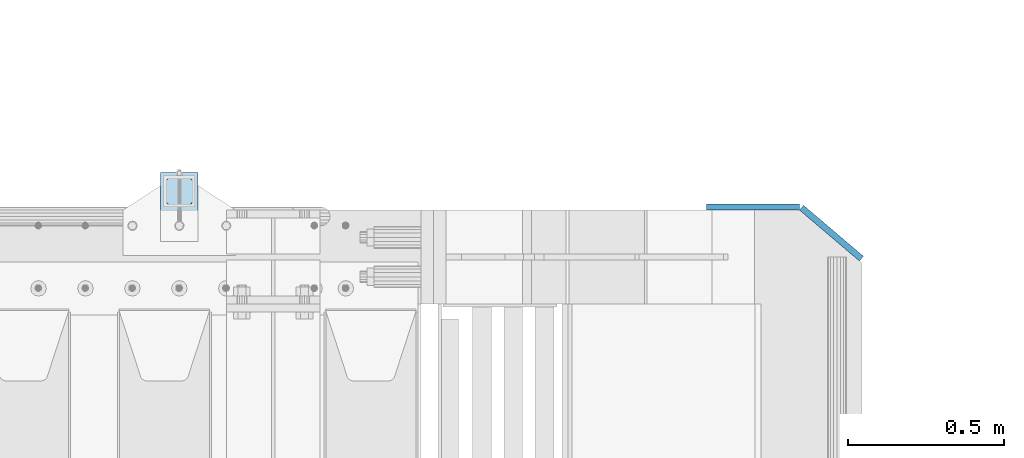
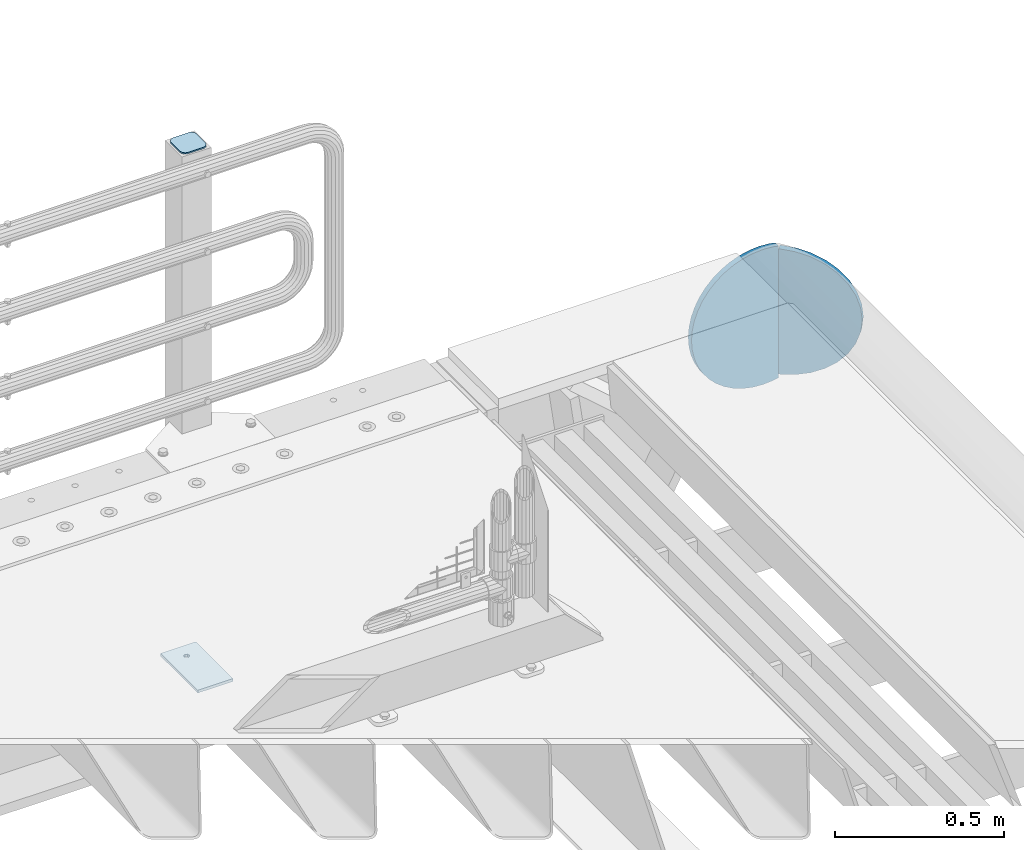
# One storey, part 253 of 270: 4 plates.
"""IFC2X3 building model written with IfcOpenShell, lengths in millimetres."""

from ifc_helpers import new_model, si_unit, frame, origin_with_axes, place, context, subcontext, project, spatial, faceted_brep, material, type_object, element, save


model = new_model("IFC2X3")

# Units and contexts
model_context = context("Model", 3, precision=1e-05, world=origin_with_axes())
body_context = subcontext(model_context, "Body", "Model", "MODEL_VIEW")
ifc_project = project(units=[si_unit("LENGTHUNIT", "METRE", prefix="MILLI"), si_unit("AREAUNIT", "SQUARE_METRE"), si_unit("VOLUMEUNIT", "CUBIC_METRE"), si_unit("MASSUNIT", "GRAM", prefix="KILO"), si_unit("TIMEUNIT", "SECOND"), si_unit("PLANEANGLEUNIT", "RADIAN"), si_unit("SOLIDANGLEUNIT", "STERADIAN"), si_unit("THERMODYNAMICTEMPERATUREUNIT", "DEGREE_CELSIUS"), si_unit("LUMINOUSINTENSITYUNIT", "LUMEN")], contexts=[model_context])

# Site, building, storey
site_placement = place(None, origin_with_axes())
site = spatial("IfcSite", under=ifc_project, at=site_placement, CompositionType="ELEMENT")
building_placement = place(site_placement, origin_with_axes())
building = spatial("IfcBuilding", under=site, at=building_placement, Name="Standard", CompositionType="ELEMENT")
storey_placement = place(building_placement, origin_with_axes())
storey = spatial("IfcBuildingStorey", under=building, at=storey_placement, Name="Undefined", CompositionType="ELEMENT", Elevation=0.0)

# Plates
ifc_material_1 = material(Name="STEEL/S355J2")
plate_type_1 = type_object("IfcPlateType", PredefinedType="NOTDEFINED")
plate_1_placement = place(storey_placement, frame((19558.0000000001, -14949.9999999998, -850.000000000002), z_axis=(0.0, 1.0, 0.0), x_axis=(1.0, 0.0, 0.0)))
element("IfcPlate", 1, at=plate_1_placement, inside=storey, type_object=plate_type_1, material=ifc_material_1, context=body_context, shape_type="Brep", body=[
    faceted_brep([(66.3639610305399, -5.0, 163.636038969114), (66.3639610305399, 5.0, 163.636038969114), (59.9999999998618, 5.0, 160.999999999793), (59.9999999998618, -5.0, 160.999999999793), (53.6360389691836, 5.0, 163.636038969114), (53.6360389691836, -5.0, 163.636038969114), (50.9999999998618, 5.0, 169.999999999793), (50.9999999998618, -5.0, 169.999999999793), (53.6360389691836, 5.0, 176.363961030471), (53.6360389691836, -5.0, 176.363961030471), (59.9999999998618, 5.0, 178.999999999793), (59.9999999998618, -5.0, 178.999999999793), (66.3639610305399, 5.0, 176.363961030471), (66.3639610305399, -5.0, 176.363961030471), (68.9999999998618, 5.0, 169.999999999793), (68.9999999998618, -5.0, 169.999999999793), (120.0, -5.0, 0.0), (120.0, -5.0, 220.0), (0.0, -5.0, 220.0), (0.0, -5.0, 0.0), (0.0, 5.0, 0.0), (120.0, 5.0, 0.0), (120.0, 5.0, 220.0), (0.0, 5.0, 220.0)], [[[0, 1, 2, 3]], [[3, 2, 4, 5]], [[5, 4, 6, 7]], [[7, 6, 8, 9]], [[9, 8, 10, 11]], [[11, 10, 12, 13]], [[13, 12, 14, 15]], [[15, 14, 1, 0]], [[16, 17, 18, 19], [3, 5, 7, 9, 11, 13, 15, 0]], [[16, 19, 20, 21]], [[17, 16, 21, 22]], [[18, 17, 22, 23]], [[19, 18, 23, 20]], [[22, 21, 20, 23], [10, 8, 6, 4, 2, 1, 14, 12]]]),
])
plate_type_2 = type_object("IfcPlateType", PredefinedType="NOTDEFINED")
plate_2_placement = place(storey_placement, frame((19662.0000000001, -14833.9999999998, 1012.50000000001), z_axis=(0.0, 1.0, 0.0), x_axis=(-1.0, 0.0, 0.0)))
element("IfcPlate", 2, at=plate_2_placement, inside=storey, type_object=plate_type_2, material=ifc_material_1, context=body_context, shape_type="Brep", body=[
    faceted_brep([(0.0, -2.5, 19.0), (0.0, -2.5, 69.0), (0.0, 2.5, 69.0), (0.0, 2.5, 19.0), (0.476369668544066, -2.5, 73.2278977451697), (0.476369668544066, 2.5, 73.2278977451697), (1.88159150985302, -2.5, 77.2437910432327), (1.88159150985302, 2.5, 77.2437910432327), (4.14520183310742, -2.5, 80.8463062353167), (4.14520183310742, 2.5, 80.8463062353167), (7.15369376468516, -2.5, 83.8547981668926), (7.15369376468516, 2.5, 83.8547981668926), (10.7562089567655, -2.5, 86.1184084901452), (10.7562089567655, 2.5, 86.1184084901452), (14.7721022548285, -2.5, 87.5236303314541), (14.7721022548285, 2.5, 87.5236303314541), (19.0, -2.5, 88.0), (19.0, 2.5, 88.0), (69.0, -2.5, 88.0), (69.0, 2.5, 88.0), (73.2278977451715, -2.5, 87.5236303314541), (73.2278977451715, 2.5, 87.5236303314541), (77.2437910432345, -2.5, 86.1184084901452), (77.2437910432345, 2.5, 86.1184084901452), (80.8463062353148, -2.5, 83.8547981668926), (80.8463062353148, 2.5, 83.8547981668926), (83.8547981668926, -2.5, 80.8463062353167), (83.8547981668926, 2.5, 80.8463062353167), (86.118408490147, -2.5, 77.2437910432345), (86.118408490147, 2.5, 77.2437910432345), (87.5236303314559, -2.5, 73.2278977451697), (87.5236303314559, 2.5, 73.2278977451697), (88.0, -2.5, 69.0), (88.0, 2.5, 69.0), (88.0, -2.5, 19.0), (88.0, 2.5, 19.0), (87.5236303314559, -2.5, 14.7721022548303), (87.5236303314559, 2.5, 14.7721022548303), (86.118408490147, -2.5, 10.7562089567673), (86.118408490147, 2.5, 10.7562089567673), (83.8547981668926, -2.5, 7.15369376468334), (83.8547981668926, 2.5, 7.15369376468334), (80.8463062353148, -2.5, 4.14520183310742), (80.8463062353148, 2.5, 4.14520183310742), (77.2437910432345, -2.5, 1.88159150985484), (77.2437910432345, 2.5, 1.88159150985484), (73.2278977451715, -2.5, 0.476369668545885), (73.2278977451715, 2.5, 0.476369668545885), (69.0, -2.5, 0.0), (69.0, 2.5, 0.0), (19.0, -2.5, 0.0), (19.0, 2.5, 0.0), (14.7721022548285, -2.5, 0.476369668545885), (14.7721022548285, 2.5, 0.476369668545885), (10.7562089567655, -2.5, 1.88159150985484), (10.7562089567655, 2.5, 1.88159150985484), (7.15369376468516, -2.5, 4.14520183310742), (7.15369376468516, 2.5, 4.14520183310742), (4.14520183310742, -2.5, 7.15369376468334), (4.14520183310742, 2.5, 7.15369376468334), (1.88159150985302, -2.5, 10.7562089567673), (1.88159150985302, 2.5, 10.7562089567673), (0.476369668544066, -2.5, 14.7721022548303), (0.476369668544066, 2.5, 14.7721022548303)], [[[0, 1, 2, 3]], [[1, 4, 5, 2]], [[4, 6, 7, 5]], [[6, 8, 9, 7]], [[8, 10, 11, 9]], [[10, 12, 13, 11]], [[12, 14, 15, 13]], [[14, 16, 17, 15]], [[16, 18, 19, 17]], [[18, 20, 21, 19]], [[20, 22, 23, 21]], [[22, 24, 25, 23]], [[24, 26, 27, 25]], [[26, 28, 29, 27]], [[28, 30, 31, 29]], [[30, 32, 33, 31]], [[32, 34, 35, 33]], [[34, 36, 37, 35]], [[36, 38, 39, 37]], [[38, 40, 41, 39]], [[40, 42, 43, 41]], [[42, 44, 45, 43]], [[44, 46, 47, 45]], [[46, 48, 49, 47]], [[48, 50, 51, 49]], [[50, 52, 53, 51]], [[52, 54, 55, 53]], [[54, 56, 57, 55]], [[56, 58, 59, 57]], [[58, 60, 61, 59]], [[60, 62, 63, 61]], [[62, 0, 3, 63]], [[5, 7, 9, 11, 13, 15, 17, 19, 21, 23, 25, 27, 29, 31, 33, 35, 37, 39, 41, 43, 45, 47, 49, 51, 53, 55, 57, 59, 61, 63, 3, 2]], [[62, 60, 58, 56, 54, 52, 50, 48, 46, 44, 42, 40, 38, 36, 34, 32, 30, 28, 26, 24, 22, 20, 18, 16, 14, 12, 10, 8, 6, 4, 1, 0]]]),
])
ifc_material_2 = material(Name="STEEL/S355N")
plate_type_3 = type_object("IfcPlateType", PredefinedType="NOTDEFINED")
plate_3_placement = place(storey_placement, frame((21789.9988298906, -14840.0, -498.000000000001), z_axis=(0.0, 0.0, 1.0), x_axis=(-1.0, 0.0, 0.0)))
element("IfcPlate", 3, at=plate_3_placement, inside=storey, type_object=plate_type_3, material=ifc_material_2, context=body_context, shape_type="Brep", body=[
    faceted_brep([(244.0, -10.0, 0.0), (209.275179461318, -10.0, 2.48356818105242), (209.275179461318, 10.0, 2.48356818105242), (244.0, 10.0, 0.0), (278.724820538682, -10.0, 2.48356818105236), (278.724820538682, 10.0, 2.48356818105236), (312.742743869308, -10.0, 9.88371443806261), (312.742743869308, 10.0, 9.88371443806261), (345.361263172461, -10.0, 22.0497931334975), (345.361263172461, 10.0, 22.0497931334975), (375.916359459166, -10.0, 38.7341379891918), (375.916359459166, 10.0, 38.7341379891918), (403.78601908265, -10.0, 59.597103857561), (403.78601908265, 10.0, 59.597103857561), (428.402896142437, -10.0, 84.2139809173505), (428.402896142437, 10.0, 84.2139809173505), (449.265862010809, -10.0, 112.083640540834), (449.265862010809, 10.0, 112.083640540834), (465.950206866502, -10.0, 142.63873682754), (465.950206866502, 10.0, 142.63873682754), (478.116285561937, -10.0, 175.257256130691), (478.116285561937, 10.0, 175.257256130691), (485.516431818949, -10.0, 209.275179461318), (485.516431818949, 10.0, 209.275179461318), (488.0, -10.0, 244.0), (488.0, 10.0, 244.0), (485.516431818949, -10.0, 278.724820538682), (485.516431818949, 10.0, 278.724820538682), (478.116285561937, -10.0, 312.742743869309), (478.116285561937, 10.0, 312.742743869309), (465.950206866502, -10.0, 345.36126317246), (465.950206866502, 10.0, 345.36126317246), (449.265862010809, -10.0, 375.916359459166), (449.265862010809, 10.0, 375.916359459166), (428.402896142437, -10.0, 403.78601908265), (428.402896142437, 10.0, 403.78601908265), (403.78601908265, -10.0, 428.402896142439), (403.78601908265, 10.0, 428.402896142439), (375.916359459166, -10.0, 449.265862010808), (375.916359459166, 10.0, 449.265862010808), (345.361263172461, -10.0, 465.950206866503), (345.361263172461, 10.0, 465.950206866503), (312.742743869308, -10.0, 478.116285561937), (312.742743869308, 10.0, 478.116285561937), (278.724820538682, -10.0, 485.516431818948), (278.724820538682, 10.0, 485.516431818948), (244.0, -10.0, 488.0), (244.0, 10.0, 488.0), (209.275179461318, -10.0, 485.516431818948), (209.275179461318, 10.0, 485.516431818948), (190.055415081217, -10.0, 481.335427997648), (190.05854791337, -10.0, 6.66389049643237), (190.053997906722, 10.0, 6.66488028979336), (190.050865087636, 10.0, 481.334438207129)], [[[0, 1, 2, 3]], [[4, 0, 3, 5]], [[6, 4, 5, 7]], [[8, 6, 7, 9]], [[10, 8, 9, 11]], [[12, 10, 11, 13]], [[14, 12, 13, 15]], [[16, 14, 15, 17]], [[18, 16, 17, 19]], [[20, 18, 19, 21]], [[22, 20, 21, 23]], [[24, 22, 23, 25]], [[26, 24, 25, 27]], [[28, 26, 27, 29]], [[30, 28, 29, 31]], [[32, 30, 31, 33]], [[34, 32, 33, 35]], [[36, 34, 35, 37]], [[38, 36, 37, 39]], [[40, 38, 39, 41]], [[42, 40, 41, 43]], [[44, 42, 43, 45]], [[46, 44, 45, 47]], [[48, 46, 47, 49]], [[1, 0, 4, 6, 8, 10, 12, 14, 16, 18, 20, 22, 24, 26, 28, 30, 32, 34, 36, 38, 40, 42, 44, 46, 48, 50, 51]], [[2, 1, 51, 52]], [[49, 47, 45, 43, 41, 39, 37, 35, 33, 31, 29, 27, 25, 23, 21, 19, 17, 15, 13, 11, 9, 7, 5, 3, 2, 52, 53]], [[48, 49, 53, 50]], [[52, 51, 50, 53]]]),
])
plate_type_4 = type_object("IfcPlateType", PredefinedType="NOTDEFINED")
plate_4_placement = place(storey_placement, frame((21643.6680552572, -14874.0468507943, -30.6119535183306), z_axis=(-0.0673151699806107, 0.0572188599835183, -0.996089689713064), x_axis=(-0.758954680570074, 0.645122052634529, 0.0883477789499519)))
element("IfcPlate", 4, at=plate_4_placement, inside=storey, type_object=plate_type_4, material=ifc_material_2, context=body_context, shape_type="Brep", body=[
    faceted_brep([(0.0, -10.0, 0.0), (-48.0501251221758, -10.0000000000005, 8.67006015777633), (-48.0501251221722, 9.99999999999591, 8.67006015777633), (0.0, 10.0, 0.0), (-93.1325836184551, -10.0000000000018, 25.6772422790527), (-93.1325836184515, 10.0, 25.6772422790532), (-133.519607544509, -10.0000000000027, 50.367210388184), (-133.519607544506, 9.99999999999727, 50.3672103881836), (-167.65461731048, -10.0000000000014, 81.7923126220703), (-167.65461731048, 10.0000000000005, 81.7923126220703), (-194.1166534437, -10.0000000000027, 118.75399017334), (-194.116653443696, 9.99999999999909, 118.75399017334), (-212.21937561212, -10.0000000000005, 159.802307128907), (-212.219375612123, 9.99999999999955, 159.802307128906), (-220.935668947561, -10.0000000000036, 203.390228271484), (-220.935668947564, 9.99999999999818, 203.390228271484), (-220.042388918759, -10.0000000000014, 247.831420898438), (-220.042388918755, 9.99999999999682, 247.831420898438), (-209.448760989551, -10.0000000000018, 291.430206298828), (-209.448760989551, 9.99999999999818, 291.430206298829), (-189.931198123792, -10.0000000000014, 332.477691650391), (-189.931198123792, 9.99999999999864, 332.477691650391), (-161.872329715996, -10.0000000000023, 369.429595947266), (-161.872329715996, 9.99999999999955, 369.429595947266), (-126.473861698767, -10.0000000000018, 400.854248046875), (-126.473861698767, 9.99999999999818, 400.854248046875), (-85.095474247868, -10.0000000000032, 425.544403076172), (-85.0954742478643, 9.99999999999864, 425.544403076172), (-39.3266487170476, -10.0000000000041, 442.551971435547), (-39.3266487170476, 9.99999999999773, 442.551971435547), (9.07161902882581, -10.0000000000023, 451.221954345703), (9.07161902882581, 9.99999999999773, 451.221954345703), (49.1691665649378, -10.0000000000027, 5.13864506501704e-11), (49.1691665649341, 9.99999999999909, 5.18411980010569e-11)], [[[0, 1, 2, 3]], [[1, 4, 5, 2]], [[4, 6, 7, 5]], [[6, 8, 9, 7]], [[8, 10, 11, 9]], [[10, 12, 13, 11]], [[12, 14, 15, 13]], [[14, 16, 17, 15]], [[16, 18, 19, 17]], [[18, 20, 21, 19]], [[20, 22, 23, 21]], [[22, 24, 25, 23]], [[24, 26, 27, 25]], [[26, 28, 29, 27]], [[28, 30, 31, 29]], [[30, 32, 33, 31]], [[32, 0, 3, 33]], [[5, 7, 9, 11, 13, 15, 17, 19, 21, 23, 25, 27, 29, 31, 33, 3, 2]], [[32, 30, 28, 26, 24, 22, 20, 18, 16, 14, 12, 10, 8, 6, 4, 1, 0]]]),
])

save(model, "model.ifc")
